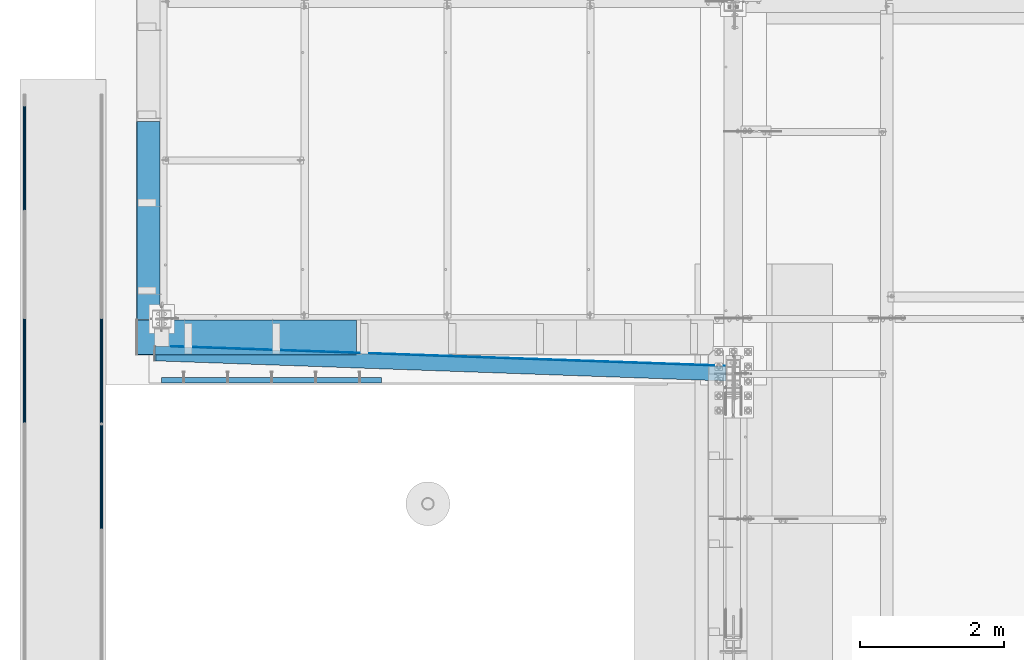
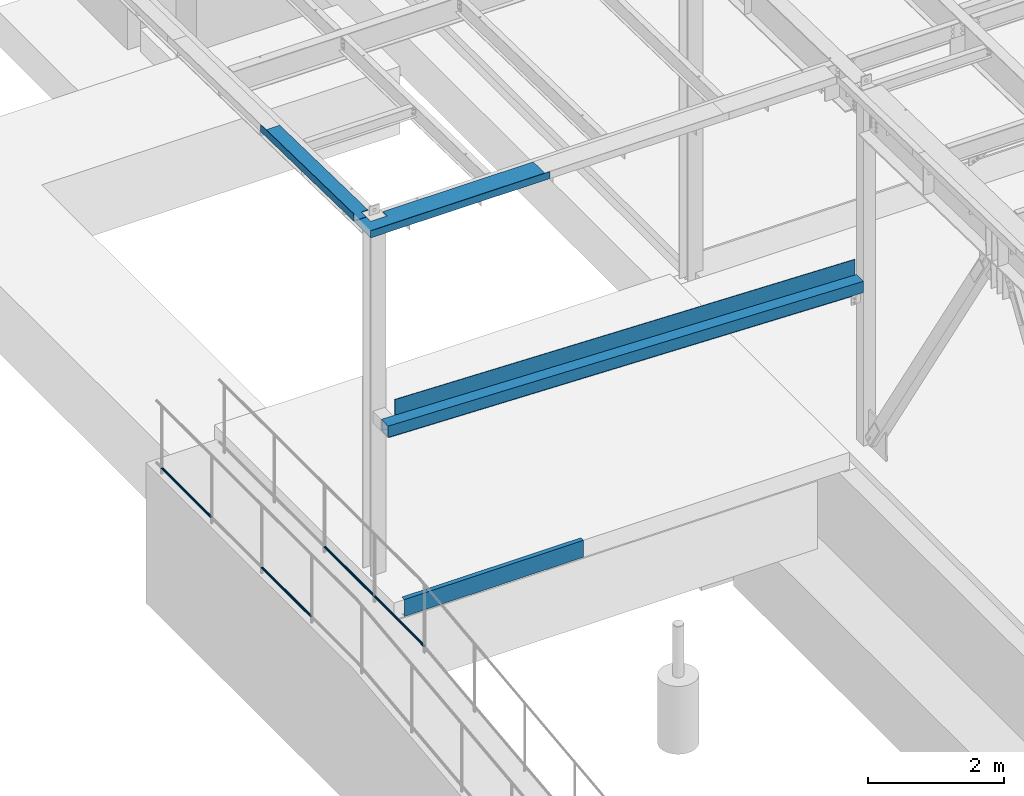
# One storey, part 1046 of 1763: 10 beams, 7 elements without a shape of their own.
"""IFC2X3 building model written with IfcOpenShell, lengths in millimetres."""

from ifc_helpers import new_model, si_unit, frame, origin_with_axes, place, context, subcontext, project, spatial, faceted_brep, material, type_object, element, aggregate, save


model = new_model("IFC2X3")

# Units and contexts
model_context = context("Model", 3, precision=1e-05, world=origin_with_axes())
body_context = subcontext(model_context, "Body", "Model", "MODEL_VIEW")
ifc_project = project(units=[si_unit("LENGTHUNIT", "METRE", prefix="MILLI"), si_unit("AREAUNIT", "SQUARE_METRE"), si_unit("VOLUMEUNIT", "CUBIC_METRE"), si_unit("MASSUNIT", "GRAM", prefix="KILO"), si_unit("TIMEUNIT", "SECOND"), si_unit("PLANEANGLEUNIT", "RADIAN"), si_unit("SOLIDANGLEUNIT", "STERADIAN"), si_unit("THERMODYNAMICTEMPERATUREUNIT", "DEGREE_CELSIUS"), si_unit("LUMINOUSINTENSITYUNIT", "LUMEN")], contexts=[model_context])

# Site, building, storey
site_placement = place(None, origin_with_axes())
site = spatial("IfcSite", under=ifc_project, at=site_placement, CompositionType="ELEMENT")
building_placement = place(site_placement, origin_with_axes())
building = spatial("IfcBuilding", under=site, at=building_placement, Name="Undefined", CompositionType="ELEMENT")
storey_placement = place(building_placement, origin_with_axes())
storey = spatial("IfcBuildingStorey", under=building, at=storey_placement, Name="Undefined", CompositionType="ELEMENT", Elevation=0.0)

# Assembly, beam
assembly_1_placement = place(storey_placement, origin_with_axes())
assembly_1 = element("IfcElementAssembly", 1, at=assembly_1_placement, inside=storey, Name="GUARDRAIL", AssemblyPlace="NOTDEFINED", PredefinedType="RIGID_FRAME")
ifc_material_1 = material(Name="STEEL/A513")
beam_type_1 = type_object("IfcBeamType", PredefinedType="NOTDEFINED")
beam_1_placement = place(assembly_1_placement, frame((-97200.6527017878, 10786.2772271783, 6031.68570659609), z_axis=(0.0, -4.62400000105845e-06, 0.999999999989309), x_axis=(0.0, 0.999999999989309, 4.62400000047487e-06)))
beam_1 = element("IfcBeam", 2, at=beam_1_placement, type_object=beam_type_1, material=ifc_material_1, Name="GUARDRAIL", context=body_context, shape_type="Brep", body=[
    faceted_brep([(1458.86834302404, -9.52499999999418, 16.4977839423982), (1458.86831781334, -9.52499999999418, 11.4667123802628), (1458.37489860333, -7.68349999999919, 13.3082123802624), (1456.31612129975, 0.0, 15.3670000003058), (1456.31613975526, 0.0, 19.050000000304), (1458.37489860332, 7.68349999999919, 13.3082123802624), (1458.86831781334, 9.52499999999418, 11.4667123802628), (1458.86834302404, 9.52499999999418, 16.4977839423982), (1475.3660442957, 19.0500000000029, 3.11956682708114e-10), (1465.8410920256, 16.4977839420899, 9.52500000030795), (1465.84099656603, 16.4977839420899, -9.52499999968768), (1462.65151123576, 13.3082123799541, 7.6835000003075), (1464.71026035381, 15.3669999999984, 3.09228198602796e-10), (1462.65143423172, 13.3082123799541, -7.68349999968814), (1458.86820289393, 9.52499999999418, -11.4667123796444), (1458.86817768322, 9.52499999999418, -16.4977839417807), (1458.37476522842, 7.68349999999919, -13.308212379643), (1456.31596729164, 0.0, -15.3669999996882), (1456.31594883613, 0.0, -19.0499999996873), (1458.86820289393, -9.52499999999418, -11.4667123796444), (1458.86817768322, -9.52499999999418, -16.4977839417807), (1458.37476522842, -7.68349999999919, -13.308212379643), (1475.36604429593, -19.0500000000029, 3.11956682708114e-10), (1465.84099656603, -16.4977839420899, -9.52499999968768), (1465.8410920256, -16.4977839420899, 9.52500000030795), (1462.65143423172, -13.3082123799541, -7.68349999968814), (1464.71026035381, -15.3669999999984, 3.09228198602796e-10), (1462.65151123576, -13.3082123799541, 7.6835000003075), (11.6909965485302, -16.4977839420899, -9.524999999996), (18.6637455500822, -9.52499999999418, -16.4977839420862), (2.16604427796847, 19.0500000000029, 0.0), (11.6909965485302, 16.4977839420899, -9.524999999996), (11.6910920080991, 16.4977839420899, 9.52499999999964), (18.6639108909039, 9.52499999999418, 16.4977839420944), (21.2161397379987, 0.0, 19.0500000000002), (18.6637455500822, 9.52499999999418, -16.4977839420862), (21.2159488188627, 0.0, -19.049999999992), (21.2159672743801, 0.0, -15.366999999992), (18.6637707607879, -9.52499999999418, -11.4667123799491), (19.1571899710179, -7.68349999999919, -13.3082123799486), (19.1571899710161, 7.68349999999919, -13.3082123799486), (18.6637707607879, 9.52499999999418, -11.4667123799491), (14.8805773385793, 13.3082123799541, -7.68349999999464), (12.8218282205289, 15.3669999999984, 1.81898940354586e-12), (14.8806543426181, 13.3082123799541, 7.683500000001), (18.6638856802001, 9.52499999999418, 11.4667123799572), (19.1573233459221, 7.68349999999919, 13.3082123799568), (21.2161212824831, 0.0, 15.367000000002), (19.1573233459239, -7.68349999999919, 13.3082123799568), (18.6638856802001, -9.52499999999418, 11.4667123799572), (18.6639108909039, -9.52499999999418, 16.4977839420944), (11.6910920080991, -16.4977839420899, 9.52499999999964), (2.16604427796847, -19.0500000000029, 0.0), (14.8806543426199, -13.3082123799541, 7.683500000001), (12.8218282205307, -15.3669999999984, 1.81898940354586e-12), (14.8805773385811, -13.3082123799541, -7.68349999999464)], [[[0, 1, 2, 3, 4]], [[4, 3, 5, 6, 7]], [[8, 9, 10]], [[7, 6, 11, 12, 13, 14, 15, 10, 9]], [[16, 17, 18, 15, 14]], [[19, 20, 18, 17, 21]], [[22, 23, 24]], [[24, 23, 20, 19, 25, 26, 27, 1, 0]], [[28, 29, 20, 23]], [[30, 31, 32]], [[33, 34, 4, 7]], [[32, 33, 7, 9]], [[30, 32, 9, 8]], [[31, 30, 8, 10]], [[35, 31, 10, 15]], [[36, 35, 15, 18]], [[29, 36, 18, 20]], [[37, 36, 29, 38, 39]], [[40, 41, 35, 36, 37]], [[32, 31, 35, 41, 42, 43, 44, 45, 33]], [[33, 45, 46, 47, 34]], [[34, 47, 48, 49, 50]], [[34, 50, 0, 4]], [[50, 51, 24, 0]], [[51, 52, 22, 24]], [[52, 28, 23, 22]], [[51, 28, 52]], [[50, 49, 53, 54, 55, 38, 29, 28, 51]], [[55, 54, 26, 25]], [[21, 39, 38, 55, 25, 19]], [[37, 39, 21, 17]], [[40, 37, 17, 16]], [[42, 41, 40, 16, 14, 13]], [[43, 42, 13, 12]], [[44, 43, 12, 11]], [[5, 46, 45, 44, 11, 6]], [[47, 46, 5, 3]], [[48, 47, 3, 2]], [[53, 49, 48, 2, 1, 27]], [[54, 53, 27, 26]]]),
])
aggregate(assembly_1, [beam_1])

assembly_2_placement = place(storey_placement, origin_with_axes())
assembly_2 = element("IfcElementAssembly", 3, at=assembly_2_placement, inside=storey, Name="GUARDRAIL", AssemblyPlace="NOTDEFINED", PredefinedType="RIGID_FRAME")
beam_2_placement = place(assembly_2_placement, frame((-97200.6527017878, 7842.04327145621, 6031.6857057578), z_axis=(0.0, -4.62400000105845e-06, 0.999999999989309), x_axis=(0.0, 0.999999999989309, 4.62400000047487e-06)))
beam_2 = element("IfcBeam", 4, at=beam_2_placement, type_object=beam_type_1, material=ifc_material_1, Name="GUARDRAIL", context=body_context, shape_type="Brep", body=[
    faceted_brep([(1456.7022988617, -9.52499999999418, 16.4977839416297), (1456.70227361578, -9.52499999999418, 11.4667123794916), (1456.20885441866, -7.68349999999919, 13.308212379492), (1454.15007712949, 0.0, 15.3669999995363), (1454.15009561079, 0.0, 19.0499999995363), (1456.20885441866, 7.68349999999919, 13.308212379492), (1456.70227361578, 9.52499999999418, 11.4667123794916), (1456.7022988617, 9.52499999999418, 16.4977839416297), (1473.20000001788, 19.0500000000029, -4.66570782009512e-10), (1463.67504781445, 16.4977839420899, 9.52499999953488), (1463.67495222153, 16.4977839420899, -9.52500000046166), (1460.48546701172, 13.3082123799541, 7.68349999953625), (1462.54421607599, 15.3669999999984, -4.63842297904193e-10), (1460.48538990012, 13.3082123799541, -7.68350000046121), (1456.70215853584, 9.52499999999418, -11.4667123804138), (1456.70213328991, 9.52499999999418, -16.497783942551), (1456.20872085744, 7.68349999999919, -13.3082123804143), (1454.14992290625, 0.0, -15.3670000004568), (1454.14990442495, 0.0, -19.0500000004567), (1456.70215853584, -9.52499999999418, -11.4667123804138), (1456.70213328991, -9.52499999999418, -16.497783942551), (1456.20872085744, -7.68349999999919, -13.3082123804143), (1473.20000001811, -19.0500000000029, -4.66570782009512e-10), (1463.67495222153, -16.4977839420899, -9.52500000046166), (1463.67504781445, -16.4977839420899, 9.52499999953488), (1460.48538990012, -13.3082123799541, -7.68350000046121), (1462.54421607599, -15.3669999999984, -4.63842297904193e-10), (1460.48546701172, -13.3082123799541, 7.68349999953625), (9.52499999467545, -16.4977839420899, -9.52500000000009), (16.497701156416, -9.52499999999418, -16.4977839420953), (0.0, 19.0500000000029, 0.0), (9.52499999467545, 16.4977839420899, -9.52500000000009), (9.52500000096188, 16.4977839420899, 9.52500000000009), (16.4978667281766, 9.52499999999418, 16.4977839420853), (19.0500955931329, 0.0, 19.0499999999911), (16.497701156416, 9.52499999999418, -16.4977839420953), (19.0499044073322, 0.0, -19.050000000002), (19.0499228886265, 0.0, -15.367000000002), (16.4977264023337, -9.52499999999418, -11.4667123799582), (16.9911455995534, -7.68349999999919, -13.3082123799586), (16.9911455995534, 7.68349999999919, -13.3082123799586), (16.4977264023337, 9.52499999999418, -11.4667123799582), (12.7145715564911, 13.3082123799541, -7.68350000000009), (10.6557839364468, 15.3669999999984, 0.0), (12.7145715564911, 13.3082123799541, 7.68350000000009), (16.497841482259, 9.52499999999418, 11.4667123799481), (16.991279160773, 7.68349999999919, 13.3082123799486), (19.0500771118395, 0.0, 15.3669999999911), (16.991279160773, -7.68349999999919, 13.3082123799486), (16.497841482259, -9.52499999999418, 11.4667123799481), (16.4978667281766, -9.52499999999418, 16.4977839420853), (9.52500000096188, -16.4977839420899, 9.52500000000009), (0.0, -19.0500000000029, 0.0), (12.7145715571314, -13.3082123799541, 7.68350000000009), (10.6557839370871, -15.3669999999984, 0.0), (12.7145715571314, -13.3082123799541, -7.68350000000009)], [[[0, 1, 2, 3, 4]], [[4, 3, 5, 6, 7]], [[8, 9, 10]], [[7, 6, 11, 12, 13, 14, 15, 10, 9]], [[16, 17, 18, 15, 14]], [[19, 20, 18, 17, 21]], [[22, 23, 24]], [[24, 23, 20, 19, 25, 26, 27, 1, 0]], [[28, 29, 20, 23]], [[30, 31, 32]], [[33, 34, 4, 7]], [[32, 33, 7, 9]], [[30, 32, 9, 8]], [[31, 30, 8, 10]], [[35, 31, 10, 15]], [[36, 35, 15, 18]], [[29, 36, 18, 20]], [[37, 36, 29, 38, 39]], [[40, 41, 35, 36, 37]], [[32, 31, 35, 41, 42, 43, 44, 45, 33]], [[33, 45, 46, 47, 34]], [[34, 47, 48, 49, 50]], [[34, 50, 0, 4]], [[50, 51, 24, 0]], [[51, 52, 22, 24]], [[52, 28, 23, 22]], [[51, 28, 52]], [[50, 49, 53, 54, 55, 38, 29, 28, 51]], [[55, 54, 26, 25]], [[21, 39, 38, 55, 25, 19]], [[37, 39, 21, 17]], [[40, 37, 17, 16]], [[42, 41, 40, 16, 14, 13]], [[43, 42, 13, 12]], [[44, 43, 12, 11]], [[5, 46, 45, 44, 11, 6]], [[47, 46, 5, 3]], [[48, 47, 3, 2]], [[53, 49, 48, 2, 1, 27]], [[54, 53, 27, 26]]]),
])
aggregate(assembly_2, [beam_2])

# Assembly, beams
assembly_3_placement = place(storey_placement, origin_with_axes())
assembly_3 = element("IfcElementAssembly", 5, at=assembly_3_placement, inside=storey, Name="GUARDRAIL", AssemblyPlace="NOTDEFINED", PredefinedType="RIGID_FRAME")
beam_3_placement = place(assembly_3_placement, frame((-96133.8527017878, 7842.04321744867, 6031.68571661139), z_axis=(0.0, 0.000110293999990972, 0.999999993917617), x_axis=(0.0, -0.999999993917617, 0.000110293999990572)))
beam_3 = element("IfcBeam", 6, at=beam_3_placement, type_object=beam_type_1, material=ifc_material_1, Name="GUARDRAIL", context=body_context, shape_type="Brep", body=[
    faceted_brep([(0.0, 19.0500000000029, 0.0), (9.52389918579229, 16.4977839420899, -9.52500000270356), (9.5259929141539, 16.4977839420899, 9.52499999728934), (9.5259929141539, -16.4977839420899, 9.52499999728934), (9.52389918579229, -16.4977839420899, -9.52500000270356), (0.0, -19.0500000000029, 0.0), (16.4995432561273, -9.52499999999418, 16.4977839373987), (16.4989903061414, -9.52499999999418, 11.4667123752624), (12.7153621018151, -13.3082123799541, 7.68349999638394), (10.6557299988963, -15.3669999999984, -3.02861735690385e-09), (12.7136731609353, -13.3082123799541, -7.68350000361079), (16.4964697622117, -9.52499999999418, -11.4667123846402), (16.4959168122259, -9.52499999999418, -16.4977839467765), (19.048257166618, 0.0, -15.367000005409), (19.0478523791344, 0.0, -19.0500000054071), (16.9896958093113, -7.68349999999919, -13.3082123847798), (16.9896958093104, 7.68349999999919, -13.3082123847798), (16.4964697622117, 9.52499999999418, -11.4667123846402), (16.4959168122259, 9.52499999999418, -16.4977839467765), (12.7136731609326, 13.3082123799541, -7.68350000361079), (10.6557299988926, 15.3669999999984, -3.02861735690385e-09), (12.7153621018115, 13.3082123799541, 7.68349999638394), (16.4989903061414, 9.52499999999418, 11.4667123752624), (16.4995432561273, 9.52499999999418, 16.4977839373987), (16.9926211407237, 7.68349999999919, 13.3082123751219), (19.0516350483749, 0.0, 15.3669999945805), (19.0520398358585, 0.0, 19.0499999945787), (16.9926211407255, -7.68349999999919, 13.3082123751219), (1319.9343412278, 7.68349999999919, 13.3082120047329), (1319.9343412262, 13.3082123799541, 7.68349962477896), (1321.9654584977, 13.3082123799541, 7.68349962420052), (1322.2876046557, 7.68349999999919, 13.3082120040635), (1323.98329424224, 13.3082123799541, 7.45160249476521), (1324.62548003482, 7.68349999999919, 13.0395347388976), (1456.21371452531, 7.68349999999919, -2.08307072021216), (1460.48971040597, 13.3082123799541, -8.23621854998237), (1456.70694273159, 9.52499999999418, -3.99337519920118), (1323.10605213563, 15.3669999999984, -0.181654905345567), (1462.54766257699, 15.3669999999984, -16.2067993071423), (1321.52539866214, 15.3669999999984, -3.75671334040817e-07), (1319.93434122402, 15.3669999999984, -3.75219315174036e-07), (1319.93434122183, 13.3082123799541, -7.68350037521668), (1321.08533882658, 13.3082123799541, -7.68350037554319), (1322.22881002902, 13.3082123799541, -7.81491230545726), (1460.48808908531, 13.3082123799541, -23.7041788217603), (1321.58662423644, 7.68349999999919, -13.4028445495896), (1456.21090631555, 7.68349999999919, -28.874363800388), (1456.70452310281, 9.52499999999418, -27.0774711894464), (1320.76319266858, 7.68349999999919, -13.3082127554053), (1319.93434122024, 7.68349999999919, -13.3082127551697), (1319.93434121965, 0.0, -15.3670003752131), (1320.64527899102, 0.0, -15.367000375415), (1321.35156792241, 0.0, -15.448169705568), (1454.15192626841, 0.0, -30.7100769108065), (1319.9343412186, 0.0, -19.0500003752131), (1319.93434121933, -9.52499999999418, -16.4977843173065), (1319.93434122131, -16.4977839420899, -9.52500037521531), (1319.93434122402, -19.0500000000029, -3.75219315174036e-07), (1320.97986994037, -16.4977839420899, -9.52500037551363), (1321.52539866214, -19.0500000000029, -3.75670424546115e-07), (1319.93434122672, -16.4977839420899, 9.52499962477941), (1319.93434122871, -9.52499999999418, 16.4977835668697), (1319.93434122943, 0.0, 19.0499996247754), (1319.93434122131, 16.4977839420899, -9.52500037521531), (1319.93434121933, 9.52499999999418, -16.4977843173065), (1319.93434122402, 19.0500000000029, -3.75219315174036e-07), (1319.93434122672, 16.4977839420899, 9.52499962477941), (1319.93434122871, 9.52499999999418, 16.4977835668697), (1320.58051519905, 9.52499999999418, -16.4977843174911), (1320.4343412186, 0.0, -19.0500003753541), (1320.58051519905, -9.52499999999418, -16.4977843174911), (1321.22246383085, -9.52499999999418, -16.5715594230041), (1322.01856192082, -16.4977839420899, -9.6443706906075), (1323.10605213563, -19.0500000000029, -0.181654905345567), (1322.07092738391, -16.4977839420899, 9.52499962417096), (1324.19354235044, -16.4977839420899, 9.28106087991546), (1322.47028212523, -9.52499999999418, 16.4977835661493), (1322.61645610568, 0.0, 19.0499996240133), (1322.47028212523, 9.52499999999418, 16.4977835661493), (1322.07092738391, 16.4977839420899, 9.52499962417096), (1321.52539866214, 19.0500000000029, -3.75670424546115e-07), (1320.97986994037, 16.4977839420899, -9.52500037551363), (1322.01856192082, 16.4977839420899, -9.6443706906075), (1321.22246383085, 9.52499999999418, -16.5715594230041), (1320.93107170602, 0.0, -19.1070864758694), (1454.15153768743, 0.0, -34.4172740007371), (1456.70399229131, -9.52499999999418, -32.1415965911274), (1463.67742795313, -16.4977839420899, -25.9243302864352), (1473.20331821774, -19.0500000000029, -17.4313969549685), (1463.67943785478, -16.4977839420899, -6.74917292472765), (1324.98964044041, -9.52499999999418, 16.2082496123112), (1456.70747354309, -9.52499999999418, 1.07075020247976), (1325.28103256525, 0.0, 18.7437766651783), (1324.98964044041, 9.52499999999418, 16.2082496123112), (1324.19354235044, 16.4977839420899, 9.28106087991546), (1323.10605213563, 19.0500000000029, -0.181654905345567), (1473.20340864678, 19.0500000000029, -17.4313969644472), (1463.67742795313, 16.4977839420899, -25.9243302864352), (1456.70399229131, 9.52499999999418, -32.1415965911274), (1456.70452310281, -9.52499999999418, -27.0774711894464), (1456.21090631555, -7.68349999999919, -28.8743638003871), (1321.58662423644, -7.68349999999919, -13.4028445495896), (1320.76319266858, -7.68349999999919, -13.3082127554053), (1319.93434122024, -7.68349999999919, -13.3082127551697), (1319.93434122183, -13.3082123799541, -7.68350037521668), (1321.08533882658, -13.3082123799541, -7.68350037554319), (1322.22881002902, -13.3082123799541, -7.81491230545726), (1460.4880890853, -13.3082123799541, -23.7041788217603), (1323.10605213563, -15.3669999999984, -0.181654905345567), (1462.54766257699, -15.3669999999984, -16.2067993071414), (1321.52539866214, -15.3669999999984, -3.75670424546115e-07), (1319.93434122402, -15.3669999999984, -3.75219315174036e-07), (1319.9343412262, -13.3082123799541, 7.68349962477896), (1321.9654584977, -13.3082123799541, 7.68349962420052), (1323.98329424224, -13.3082123799541, 7.45160249476521), (1460.48971040597, -13.3082123799541, -8.23621854998237), (1456.70694273159, -9.52499999999418, -3.99337519920118), (1324.62548003482, -7.68349999999919, 13.0395347388976), (1456.21371452531, -7.68349999999919, -2.08307072021216), (1322.2876046557, -7.68349999999919, 13.3082120040635), (1319.9343412278, -7.68349999999919, 13.3082120047329), (1319.93434122838, 0.0, 15.3669996247763), (1322.40551833326, 0.0, 15.3669996240733), (1324.86053634886, 0.0, 15.084859894876), (1454.15516890974, 0.0, 0.225843632748365), (1454.15555749073, 0.0, 3.93304072267892), (1456.70747354309, 9.52499999999418, 1.07075020247976), (1463.67943785478, 16.4977839420899, -6.74917292472765)], [[[0, 1, 2]], [[3, 4, 5]], [[6, 7, 8, 9, 10, 11, 12, 4, 3]], [[13, 14, 12, 11, 15]], [[16, 17, 18, 14, 13]], [[2, 1, 18, 17, 19, 20, 21, 22, 23]], [[23, 22, 24, 25, 26]], [[26, 25, 27, 7, 6]], [[28, 29, 30, 31]], [[31, 30, 32, 33]], [[34, 33, 32, 35, 36]], [[32, 37, 38, 35]], [[30, 39, 37, 32]], [[29, 40, 39, 30]], [[40, 41, 42, 39]], [[39, 42, 43, 37]], [[37, 43, 44, 38]], [[43, 45, 46, 47, 44]], [[42, 48, 45, 43]], [[41, 49, 48, 42]], [[49, 50, 51, 48]], [[48, 51, 52, 45]], [[45, 52, 53, 46]], [[54, 55, 12, 14]], [[55, 56, 4, 12]], [[57, 56, 58, 59]], [[56, 57, 5, 4]], [[57, 60, 3, 5]], [[60, 61, 6, 3]], [[61, 62, 26, 6]], [[63, 64, 18, 1]], [[65, 63, 1, 0]], [[66, 65, 0, 2]], [[67, 66, 2, 23]], [[62, 67, 23, 26]], [[64, 54, 14, 18]], [[54, 64, 68, 69]], [[55, 54, 69, 70]], [[56, 55, 70, 58]], [[58, 70, 71, 72]], [[59, 58, 72, 73]], [[74, 59, 73, 75]], [[60, 57, 59, 74]], [[61, 60, 74, 76]], [[62, 61, 76, 77]], [[67, 62, 77, 78]], [[66, 67, 78, 79]], [[65, 66, 79, 80]], [[63, 65, 80, 81]], [[64, 63, 81, 68]], [[68, 81, 82, 83]], [[69, 68, 83, 84]], [[70, 69, 84, 71]], [[71, 84, 85, 86]], [[72, 71, 86, 87]], [[73, 72, 87, 88]], [[88, 87, 89]], [[75, 73, 88, 89]], [[90, 75, 89, 91]], [[76, 74, 75, 90]], [[77, 76, 90, 92]], [[78, 77, 92, 93]], [[79, 78, 93, 94]], [[80, 79, 94, 95]], [[81, 80, 95, 82]], [[82, 95, 96, 97]], [[83, 82, 97, 98]], [[84, 83, 98, 85]], [[46, 53, 85, 98, 47]], [[99, 86, 85, 53, 100]], [[52, 101, 100, 53]], [[51, 102, 101, 52]], [[50, 103, 102, 51]], [[103, 104, 105, 102]], [[102, 105, 106, 101]], [[100, 101, 106, 107, 99]], [[106, 108, 109, 107]], [[105, 110, 108, 106]], [[104, 111, 110, 105]], [[111, 112, 113, 110]], [[110, 113, 114, 108]], [[108, 114, 115, 109]], [[89, 87, 86, 99, 107, 109, 115, 116, 91]], [[114, 117, 118, 116, 115]], [[113, 119, 117, 114]], [[112, 120, 119, 113]], [[120, 121, 122, 119]], [[119, 122, 123, 117]], [[117, 123, 124, 118]], [[91, 116, 118, 124, 125]], [[92, 90, 91, 125]], [[93, 92, 125, 126]], [[94, 93, 126, 127]], [[95, 94, 127, 96]], [[96, 127, 97]], [[126, 36, 35, 38, 44, 47, 98, 97, 127]], [[125, 124, 34, 36, 126]], [[123, 33, 34, 124]], [[122, 31, 33, 123]], [[121, 28, 31, 122]], [[28, 121, 25, 24]], [[21, 29, 28, 24, 22]], [[40, 29, 21, 20]], [[41, 40, 20, 19]], [[49, 41, 19, 17, 16]], [[50, 49, 16, 13]], [[103, 50, 13, 15]], [[10, 104, 103, 15, 11]], [[111, 104, 10, 9]], [[112, 111, 9, 8]], [[120, 112, 8, 7, 27]], [[121, 120, 27, 25]]]),
])
beam_4_placement = place(assembly_3_placement, frame((-96133.8527017878, 7842.04327145621, 6031.6857057578), z_axis=(0.0, -4.62400000105845e-06, 0.999999999989309), x_axis=(0.0, 0.999999999989309, 4.62400000047487e-06)))
beam_4 = element("IfcBeam", 7, at=beam_4_placement, type_object=beam_type_1, material=ifc_material_1, Name="GUARDRAIL", context=body_context, shape_type="Brep", body=[
    faceted_brep([(0.0, 19.0500000000029, 0.0), (9.52499999467545, 16.4977839420899, -9.52500000000009), (9.52500000096188, 16.4977839420899, 9.52500000000009), (9.52500000096188, -16.4977839420899, 9.52500000000009), (9.52499999467545, -16.4977839420899, -9.52500000000009), (0.0, -19.0500000000029, 0.0), (16.4978667281766, -9.52499999999418, 16.4977839420853), (16.497841482259, -9.52499999999418, 11.4667123799481), (12.7145715571314, -13.3082123799541, 7.68350000000009), (10.6557839370871, -15.3669999999984, 0.0), (12.7145715571314, -13.3082123799541, -7.68350000000009), (16.4977264023337, -9.52499999999418, -11.4667123799582), (16.497701156416, -9.52499999999418, -16.4977839420953), (19.0499228886265, 0.0, -15.367000000002), (19.0499044073322, 0.0, -19.050000000002), (16.9911455995534, -7.68349999999919, -13.3082123799586), (16.9911455995534, 7.68349999999919, -13.3082123799586), (16.4977264023337, 9.52499999999418, -11.4667123799582), (16.497701156416, 9.52499999999418, -16.4977839420953), (12.7145715564911, 13.3082123799541, -7.68350000000009), (10.6557839364468, 15.3669999999984, 0.0), (12.7145715564911, 13.3082123799541, 7.68350000000009), (16.497841482259, 9.52499999999418, 11.4667123799481), (16.4978667281766, 9.52499999999418, 16.4977839420853), (16.991279160773, 7.68349999999919, 13.3082123799486), (19.0500771118395, 0.0, 15.3669999999911), (19.0500955931329, 0.0, 19.0499999999911), (16.991279160773, -7.68349999999919, 13.3082123799486), (1473.20000001788, 19.0500000000029, -4.66570782009512e-10), (1463.67495222153, 16.4977839420899, -9.52500000046166), (1456.70213328991, 9.52499999999418, -16.497783942551), (1473.20000001811, -19.0500000000029, -4.66570782009512e-10), (1463.67495222153, -16.4977839420899, -9.52500000046166), (1463.67504781445, -16.4977839420899, 9.52499999953488), (1456.7022988617, -9.52499999999418, 16.4977839416297), (1456.70213328991, -9.52499999999418, -16.497783942551), (1454.14990442495, 0.0, -19.0500000004567), (1456.20872085744, 7.68349999999919, -13.3082123804143), (1454.14992290625, 0.0, -15.3670000004568), (1456.70215853584, 9.52499999999418, -11.4667123804138), (1456.70215853584, -9.52499999999418, -11.4667123804138), (1456.20872085744, -7.68349999999919, -13.3082123804143), (1460.48538990012, -13.3082123799541, -7.68350000046121), (1462.54421607599, -15.3669999999984, -4.63842297904193e-10), (1460.48546701172, -13.3082123799541, 7.68349999953625), (1456.70227361578, -9.52499999999418, 11.4667123794916), (1456.20885441866, -7.68349999999919, 13.308212379492), (1454.15007712949, 0.0, 15.3669999995363), (1454.15009561079, 0.0, 19.0499999995363), (1456.7022988617, 9.52499999999418, 16.4977839416297), (1463.67504781445, 16.4977839420899, 9.52499999953488), (1456.70227361578, 9.52499999999418, 11.4667123794916), (1460.48546701172, 13.3082123799541, 7.68349999953625), (1462.54421607599, 15.3669999999984, -4.63842297904193e-10), (1460.48538990012, 13.3082123799541, -7.68350000046121), (1456.20885441866, 7.68349999999919, 13.308212379492)], [[[0, 1, 2]], [[3, 4, 5]], [[6, 7, 8, 9, 10, 11, 12, 4, 3]], [[13, 14, 12, 11, 15]], [[16, 17, 18, 14, 13]], [[2, 1, 18, 17, 19, 20, 21, 22, 23]], [[23, 22, 24, 25, 26]], [[26, 25, 27, 7, 6]], [[1, 0, 28, 29]], [[18, 1, 29, 30]], [[31, 32, 33]], [[6, 3, 33, 34]], [[3, 5, 31, 33]], [[5, 4, 32, 31]], [[4, 12, 35, 32]], [[12, 14, 36, 35]], [[14, 18, 30, 36]], [[37, 38, 36, 30, 39]], [[40, 35, 36, 38, 41]], [[33, 32, 35, 40, 42, 43, 44, 45, 34]], [[34, 45, 46, 47, 48]], [[26, 6, 34, 48]], [[2, 23, 49, 50]], [[23, 26, 48, 49]], [[0, 2, 50, 28]], [[28, 50, 29]], [[49, 51, 52, 53, 54, 39, 30, 29, 50]], [[48, 47, 55, 51, 49]], [[25, 24, 55, 47]], [[55, 24, 22, 21, 52, 51]], [[21, 20, 53, 52]], [[20, 19, 54, 53]], [[19, 17, 16, 37, 39, 54]], [[16, 13, 38, 37]], [[13, 15, 41, 38]], [[41, 15, 11, 10, 42, 40]], [[10, 9, 43, 42]], [[9, 8, 44, 43]], [[8, 7, 27, 46, 45, 44]], [[27, 25, 47, 46]]]),
])
aggregate(assembly_3, [beam_3, beam_4])

# Assembly, beam
assembly_4_placement = place(storey_placement, origin_with_axes())
assembly_4 = element("IfcElementAssembly", 8, at=assembly_4_placement, inside=storey, Name="EMBED", AssemblyPlace="NOTDEFINED", PredefinedType="RIGID_FRAME")
ifc_material_2 = material(Name="STEEL/A36")
beam_type_2 = type_object("IfcBeamType", Name="C12X20.7", PredefinedType="NOTDEFINED")
beam_5_placement = place(assembly_4_placement, frame((-95300.2372736984, 8445.4998046875, 5181.6), z_axis=(0.0, 0.0, -1.0), x_axis=(1.0, 0.0, 0.0)))
beam_5 = element("IfcBeam", 9, at=beam_5_placement, type_object=beam_type_2, material=ifc_material_2, Name="EMBED", ObjectType="C12X20.7", context=body_context, shape_type="Brep", body=[
    faceted_brep([(0.0, 38.1000000000004, -152.4), (0.0, 38.1000000000004, 152.4), (3048.0, 38.1000000000004, 152.4), (3048.0, 38.1000000000004, -152.4), (0.0, -38.1000000000004, 152.4), (3048.0, -38.1000000000004, 152.4), (0.0, -38.1000000000004, 146.04746), (3048.0, -38.1000000000004, 146.04746), (0.0, 30.1625000000004, 134.6749275), (3048.0, 30.1625000000004, 134.6749275), (0.0, 30.1625000000004, -134.6749275), (3048.0, 30.1625000000004, -134.6749275), (0.0, -38.1000000000004, -146.04746), (3048.0, -38.1000000000004, -146.04746), (0.0, -38.1000000000004, -152.4), (3048.0, -38.1000000000004, -152.4)], [[[0, 1, 2, 3]], [[1, 4, 5, 2]], [[4, 6, 7, 5]], [[6, 8, 9, 7]], [[8, 10, 11, 9]], [[10, 12, 13, 11]], [[12, 14, 15, 13]], [[14, 0, 3, 15]], [[5, 7, 9, 11, 13, 15, 3, 2]], [[14, 12, 10, 8, 6, 4, 1, 0]]]),
])
aggregate(assembly_4, [beam_5])

# Assembly, beams
assembly_5_placement = place(storey_placement, origin_with_axes())
assembly_5 = element("IfcElementAssembly", 10, at=assembly_5_placement, inside=storey, Name="BEAM", AssemblyPlace="NOTDEFINED", PredefinedType="RIGID_FRAME")
ifc_material_3 = material()
beam_type_3 = type_object("IfcBeamType", Name="HSS8X8X3/8", PredefinedType="NOTDEFINED")
beam_6_placement = place(assembly_5_placement, frame((-95401.8372736984, 8817.38205132637, 8197.85), z_axis=(0.0, 0.0, 1.0), x_axis=(0.999379071559902, -0.0352345189844838, 0.0)))
beam_6 = element("IfcBeam", 11, at=beam_6_placement, type_object=beam_type_3, material=ifc_material_3, Name="BEAM", ObjectType="HSS8X8X3/8", context=body_context, shape_type="Brep", body=[
    faceted_brep([(6.35000000066066, 92.0750000000144, -92.0749999999998), (6.34999999959837, -92.0750000000035, -92.0749999999998), (7932.97002515306, -92.0749999941463, -92.0749999999998), (7926.47755712498, 92.0750000058661, -92.0749999999998), (6.34999999959837, -92.0750000000035, 92.0750000000007), (7932.97002515306, -92.0749999941463, 92.0750000000007), (6.35000000066066, 92.0750000000144, 92.0750000000007), (7926.47755712498, 92.0750000058661, 92.0750000000007), (6.35000000071886, 101.600000000014, -101.6), (6.35000000071886, 101.600000000014, 101.6), (7926.14173981317, 101.600000005866, 101.6), (7926.14173981317, 101.600000005866, -101.6), (6.34999999955471, -101.600000000002, 101.6), (7933.30584246486, -101.599999994148, 101.6), (6.34999999955471, -101.600000000002, -101.6), (7933.30584246486, -101.599999994148, -101.6)], [[[0, 1, 2, 3]], [[1, 4, 5, 2]], [[4, 6, 7, 5]], [[6, 0, 3, 7]], [[8, 9, 10, 11]], [[9, 12, 13, 10]], [[12, 14, 15, 13]], [[14, 8, 11, 15]], [[13, 15, 11, 10], [5, 7, 3, 2]], [[14, 12, 9, 8], [6, 4, 1, 0]]]),
])
beam_type_4 = type_object("IfcBeamType", PredefinedType="NOTDEFINED")
beam_7_placement = place(assembly_5_placement, frame((-95169.6315864143, 8915.62389678548, 8378.82500000001), z_axis=(0.0, 0.0, 1.0), x_axis=(0.999379071559902, -0.0352345189844838, 0.0)))
beam_7 = element("IfcBeam", 12, at=beam_7_placement, type_object=beam_type_4, material=ifc_material_2, Name="PLATE", context=body_context, shape_type="Brep", body=[
    faceted_brep([(0.0, 4.76249999999982, -200.025), (0.0, 4.76249999999982, 200.025), (7675.72379164037, 4.76250000566961, 200.025), (7675.72379164037, 4.76250000566961, -200.025), (-2.91038304567337e-11, -4.76250000000073, 200.025), (7675.72379164034, -4.76249999433003, 200.025), (-2.91038304567337e-11, -4.76250000000073, -200.025), (7675.72379164034, -4.76249999433003, -200.025)], [[[0, 1, 2, 3]], [[1, 4, 5, 2]], [[4, 6, 7, 5]], [[6, 0, 3, 7]], [[5, 7, 3, 2]], [[6, 4, 1, 0]]]),
])
beam_type_5 = type_object("IfcBeamType", PredefinedType="NOTDEFINED")
beam_8_placement = place(assembly_5_placement, frame((-95376.4530452807, 8816.48709454417, 8091.4875), z_axis=(0.0352345189844782, 0.999379071559902, 0.0), x_axis=(0.999379071559902, -0.0352345189844838, 0.0)))
beam_8 = element("IfcBeam", 13, at=beam_8_placement, type_object=beam_type_5, material=ifc_material_2, Name="PLATE", context=body_context, shape_type="Brep", body=[
    faceted_brep([(-5.0931703299284e-10, 4.76249999999982, -101.600000000009), (0.0, 4.76250000000243, 101.60001373291), (7726.52379153339, 4.76249999999982, 101.600000005717), (7726.52379153237, 4.76249999999982, -101.599999994301), (1.45519152283669e-11, -4.76250000000448, 101.60001373291), (7726.52379153339, -4.76249999999982, 101.600000005717), (-5.0931703299284e-10, -4.76249999999982, -101.600000000009), (7726.52379153237, -4.76249999999982, -101.599999994301)], [[[0, 1, 2, 3]], [[1, 4, 5, 2]], [[4, 6, 7, 5]], [[6, 0, 3, 7]], [[5, 7, 3, 2]], [[6, 4, 1, 0]]]),
])
aggregate(assembly_5, [beam_7, beam_8, beam_6])

# Assembly, beam
assembly_6_placement = place(storey_placement, origin_with_axes())
assembly_6 = element("IfcElementAssembly", 14, at=assembly_6_placement, inside=storey, Name="BEAM", AssemblyPlace="NOTDEFINED", PredefinedType="RIGID_FRAME")
beam_type_6 = type_object("IfcBeamType", PredefinedType="NOTDEFINED")
beam_9_placement = place(assembly_6_placement, frame((-94125.4872736984, 9283.7, 11725.1920365109), z_axis=(-1.0, 0.0, 0.0), x_axis=(0.0, -1.0, 0.0)))
beam_9 = element("IfcBeam", 15, at=beam_9_placement, type_object=beam_type_6, material=ifc_material_2, Name="BENT_PLATE", context=body_context, shape_type="Brep", body=[
    faceted_brep([(126.999999999975, -3.17499999999927, 1035.05), (126.999999999975, 3.17499999999927, 1035.05), (0.0, 3.17499999999927, 1035.05), (0.0, -3.17499999999927, 1035.05), (126.999999999975, -3.17499999999927, 1314.45002441407), (126.999999999975, 3.17499999999927, 1314.45002441407), (0.0, -3.17499999999927, 1314.45002441407), (0.0, 3.17499999999927, 1314.45002441407), (488.950012207031, -3.17499999999927, 1524.0), (488.950012207031, -3.17499999999927, -1524.0), (488.950012207031, 123.825000000001, -1524.0), (488.950012207031, 123.825000000001, 1524.0), (482.600012207033, 3.17499999999927, 1524.0), (0.0, 3.17499999999927, 1524.0), (0.0, -3.17499999999927, 1524.0), (482.600012207033, 123.825000000001, 1524.0), (482.600012207033, 3.17499999999927, -1524.0), (482.600012207033, 123.825000000001, -1524.0), (0.0, -3.17499999999927, -1523.99999999999), (0.0, 3.17499999999927, -1523.99999999999)], [[[0, 1, 2, 3]], [[4, 5, 1, 0]], [[6, 7, 5, 4]], [[8, 9, 10, 11]], [[12, 13, 14, 8, 11, 15]], [[16, 12, 15, 17]], [[11, 10, 17, 15]], [[9, 18, 19, 16, 17, 10]], [[19, 18, 3, 2]], [[13, 12, 16, 19, 2, 1, 5, 7]], [[14, 13, 7, 6]], [[3, 18, 9, 8, 14, 6, 4, 0]]]),
])
aggregate(assembly_6, [beam_9])

assembly_7_placement = place(storey_placement, origin_with_axes())
assembly_7 = element("IfcElementAssembly", 16, at=assembly_7_placement, inside=storey, Name="BEAM", AssemblyPlace="NOTDEFINED", PredefinedType="RIGID_FRAME")
beam_type_7 = type_object("IfcBeamType", PredefinedType="NOTDEFINED")
beam_10_placement = place(assembly_7_placement, frame((-95325.6372736983, 10661.4710089395, 11698.0555776695), z_axis=(0.0, -0.999802459002039, 0.0198756880000585), x_axis=(-1.0, 0.0, 0.0)))
beam_10 = element("IfcBeam", 17, at=beam_10_placement, type_object=beam_type_7, material=ifc_material_2, Name="BENT_PLATE", context=body_context, shape_type="Brep", body=[
    faceted_brep([(114.299995421999, -3.17499999989559, 1225.54999691469), (114.299995425419, 3.17500000010477, 1225.54999691469), (0.0, 3.17500000010477, 1225.55000000057), (0.0, -3.17499999989559, 1225.55000000057), (114.299991735039, -3.17499999988286, 1371.59999996701), (114.299991738459, 3.17500000011751, 1371.60000000027), (317.499975585932, -3.17500000012114, -1371.60000000027), (2.91038304567337e-11, -3.17499999963729, -1371.60000000396), (2.91038304567337e-11, 3.17500000035943, -1371.60000000396), (323.849975585938, 3.17499999988104, -1371.60000000028), (323.849975585938, -123.825002256988, -1371.60000000026), (317.500000000218, -123.824997303087, -1371.60000000397), (323.849975585938, 3.17500000012114, 1371.60000000027), (323.849975585938, -123.825002256748, 1371.60000000028), (317.500000000218, -123.824997303656, 1371.60000000394), (317.499975585932, -3.17499999988286, 1371.60000000027)], [[[0, 1, 2, 3]], [[4, 5, 1, 0]], [[6, 7, 8, 9, 10, 11]], [[9, 12, 13, 10]], [[14, 11, 10, 13]], [[15, 6, 11, 14]], [[3, 7, 6, 15, 4, 0]], [[8, 7, 3, 2]], [[12, 9, 8, 2, 1, 5]], [[15, 14, 13, 12, 5, 4]]]),
])
aggregate(assembly_7, [beam_10])

save(model, "model.ifc")
